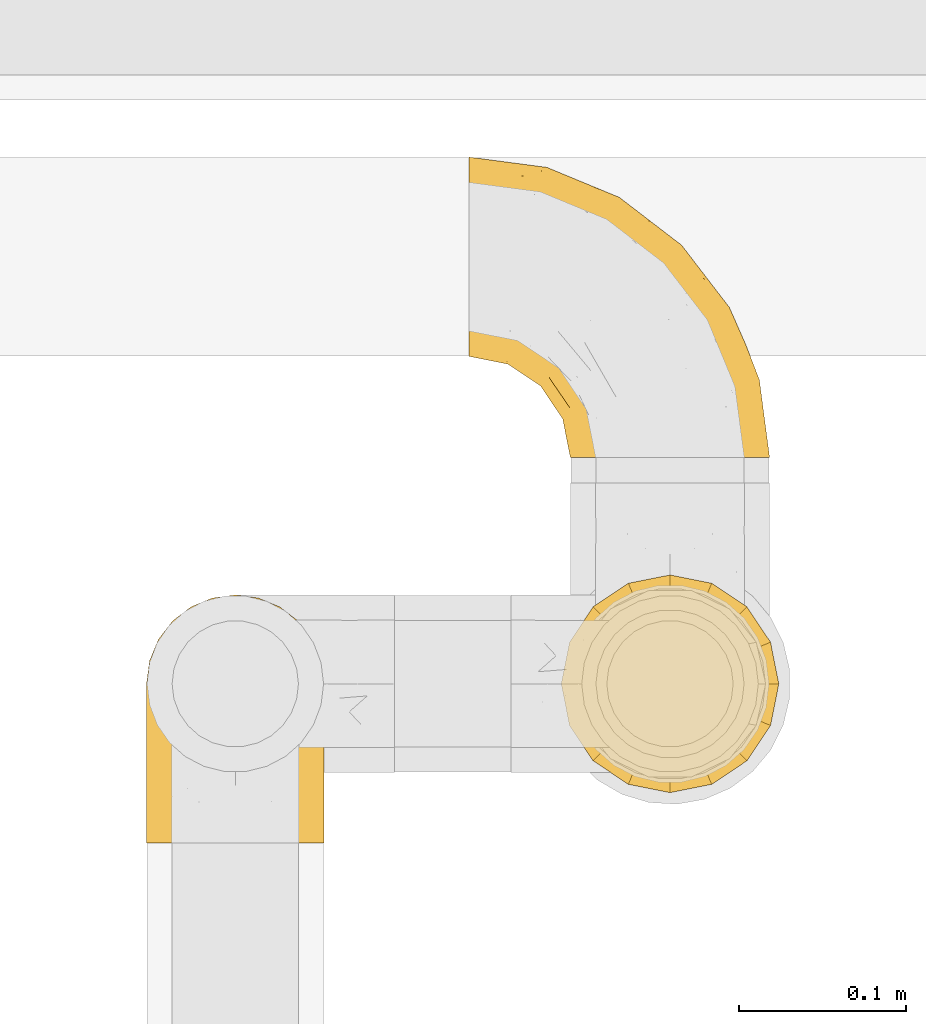
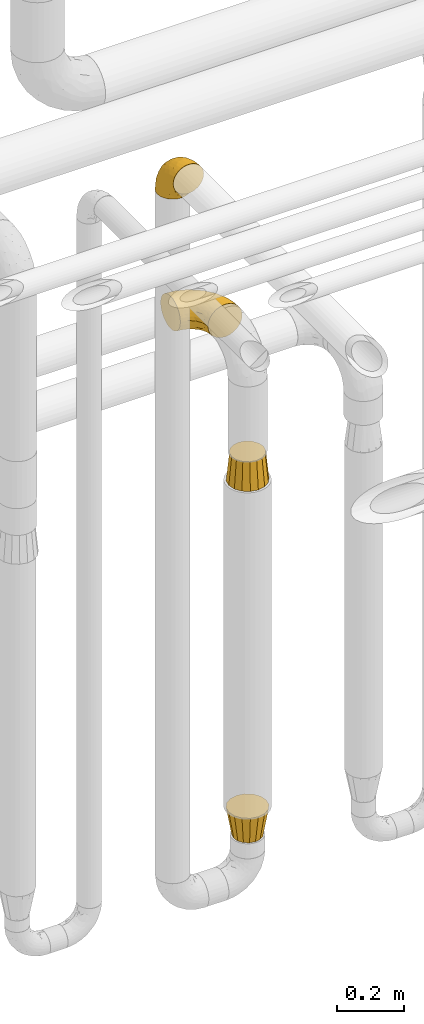
# One storey, part 477 of 827: 4 coverings.
"""IFC2X3 building model written with IfcOpenShell, lengths in millimetres."""

from ifc_helpers import new_model, entity, si_unit, converted_unit, derived_unit, direction, frame, origin, place, context, subcontext, project, spatial, faceted_brep, element, save


model = new_model("IFC2X3")

# Units and contexts
model_context = context("Model", 3, precision=0.01, world=origin(), true_north=direction((6.12303176911189e-17, 1.0)))
body_context = subcontext(model_context, "Body", "Model", "MODEL_VIEW")
ifc_project = project(units=[si_unit("LENGTHUNIT", "METRE", prefix="MILLI"), si_unit("AREAUNIT", "SQUARE_METRE"), si_unit("VOLUMEUNIT", "CUBIC_METRE"), converted_unit("PLANEANGLEUNIT", "DEGREE", entity("IfcRatioMeasure", 0.0174532925199433), si_unit("PLANEANGLEUNIT", "RADIAN"), dimensions=[0, 0, 0, 0, 0, 0, 0]), si_unit("MASSUNIT", "GRAM", prefix="KILO"), derived_unit("MASSDENSITYUNIT", [(si_unit("MASSUNIT", "GRAM", prefix="KILO"), 1), (si_unit("LENGTHUNIT", "METRE"), -3)]), derived_unit("MOMENTOFINERTIAUNIT", [(si_unit("LENGTHUNIT", "METRE"), 4)]), si_unit("TIMEUNIT", "SECOND"), si_unit("FREQUENCYUNIT", "HERTZ"), si_unit("THERMODYNAMICTEMPERATUREUNIT", "DEGREE_CELSIUS"), derived_unit("THERMALTRANSMITTANCEUNIT", [(si_unit("MASSUNIT", "GRAM", prefix="KILO"), 1), (si_unit("THERMODYNAMICTEMPERATUREUNIT", "KELVIN"), -1), (si_unit("TIMEUNIT", "SECOND"), -3)]), derived_unit("VOLUMETRICFLOWRATEUNIT", [(si_unit("LENGTHUNIT", "METRE"), 3), (si_unit("TIMEUNIT", "SECOND"), -1)]), derived_unit("MASSFLOWRATEUNIT", [(si_unit("MASSUNIT", "GRAM", prefix="KILO"), 1), (si_unit("TIMEUNIT", "SECOND"), -1)]), derived_unit("ROTATIONALFREQUENCYUNIT", [(si_unit("TIMEUNIT", "SECOND"), -1)]), si_unit("ELECTRICCURRENTUNIT", "AMPERE"), si_unit("ELECTRICVOLTAGEUNIT", "VOLT"), si_unit("POWERUNIT", "WATT"), si_unit("FORCEUNIT", "NEWTON", prefix="KILO"), si_unit("ILLUMINANCEUNIT", "LUX"), si_unit("LUMINOUSFLUXUNIT", "LUMEN"), si_unit("LUMINOUSINTENSITYUNIT", "CANDELA"), derived_unit("USERDEFINED", [(si_unit("MASSUNIT", "GRAM", prefix="KILO"), -1), (si_unit("LENGTHUNIT", "METRE"), -2), (si_unit("TIMEUNIT", "SECOND"), 3), (si_unit("LUMINOUSFLUXUNIT", "LUMEN"), 1)]), derived_unit("LINEARVELOCITYUNIT", [(si_unit("LENGTHUNIT", "METRE"), 1), (si_unit("TIMEUNIT", "SECOND"), -1)]), si_unit("PRESSUREUNIT", "PASCAL"), derived_unit("USERDEFINED", [(si_unit("LENGTHUNIT", "METRE"), -2), (si_unit("MASSUNIT", "GRAM", prefix="KILO"), 1), (si_unit("TIMEUNIT", "SECOND"), -2)]), derived_unit("LINEARFORCEUNIT", [(si_unit("MASSUNIT", "GRAM", prefix="KILO"), 1), (si_unit("LENGTHUNIT", "METRE"), 1), (si_unit("TIMEUNIT", "SECOND"), -2), (si_unit("LENGTHUNIT", "METRE"), -1)]), derived_unit("PLANARFORCEUNIT", [(si_unit("MASSUNIT", "GRAM", prefix="KILO"), 1), (si_unit("LENGTHUNIT", "METRE"), 1), (si_unit("TIMEUNIT", "SECOND"), -2), (si_unit("LENGTHUNIT", "METRE"), -2)])], contexts=[model_context])

# Site, building, storey
site_placement = place(None, origin())
site = spatial("IfcSite", under=ifc_project, at=site_placement, CompositionType="ELEMENT")
building_placement = place(site_placement, origin())
building = spatial("IfcBuilding", under=site, at=building_placement, CompositionType="ELEMENT")
storey_placement = place(building_placement, frame((0.0, 0.0, 28200.0)))
storey = spatial("IfcBuildingStorey", under=building, at=storey_placement, Name="08", CompositionType="ELEMENT", Elevation=28200.0)

# Coverings
covering_1_placement = place(storey_placement, frame((57933.24, 17403.4, 2953.4)))
element("IfcCovering", 1, at=covering_1_placement, inside=storey, Name=":ADSK_", ObjectType=":ADSK_", PredefinedType="INSULATION", context=body_context, shape_type="Brep", body=[
    faceted_brep([(66.44, 1.6, 148.32), (54.65, 1.6, 149.65), (42.84, 1.6, 148.31), (31.62, 1.6, 144.39), (21.56, 1.6, 138.06), (13.16, 1.6, 129.66), (6.84, 1.6, 119.6), (2.92, 1.6, 108.39), (1.6, 1.6, 96.6), (2.93, 1.6, 84.79), (6.85, 1.6, 73.57), (13.18, 1.6, 63.51), (21.58, 1.6, 55.11), (31.64, 1.6, 48.79), (42.85, 1.6, 44.87), (54.65, 1.6, 43.55), (66.46, 1.6, 44.88), (77.67, 1.6, 48.8), (87.73, 1.6, 55.13), (96.13, 1.6, 63.53), (102.45, 1.6, 73.59), (106.37, 1.6, 84.8), (107.7, 1.6, 96.6), (106.36, 1.6, 108.41), (102.44, 1.6, 119.62), (96.11, 1.6, 129.68), (87.71, 1.6, 138.08), (77.65, 1.6, 144.4), (40.91, 45.35, 1.6), (28.12, 50.65, 1.6), (17.13, 59.08, 1.6), (8.7, 70.07, 1.6), (3.4, 82.86, 1.6), (1.6, 96.6, 1.6), (3.4, 110.33, 1.6), (8.7, 123.12, 1.6), (17.13, 134.11, 1.6), (28.12, 142.54, 1.6), (40.91, 147.84, 1.6), (54.65, 149.65, 1.6), (68.38, 147.84, 1.6), (81.17, 142.54, 1.6), (92.16, 134.11, 1.6), (100.59, 123.12, 1.6), (105.89, 110.33, 1.6), (107.7, 96.6, 1.6), (105.89, 82.86, 1.6), (100.59, 70.07, 1.6), (92.16, 59.08, 1.6), (81.17, 50.65, 1.6), (68.38, 45.35, 1.6), (54.65, 43.55, 1.6), (85.53, 137.19, 27.97), (73.42, 141.79, 37.09), (83.77, 128.89, 58.27), (64.22, 146.54, 27.13), (54.65, 144.6, 39.91), (96.72, 69.77, 109.11), (93.36, 94.41, 94.41), (84.47, 87.22, 110.94), (71.37, 117.2, 89.69), (54.65, 129.81, 75.62), (54.65, 106.28, 106.28), (103.47, 101.45, 60.12), (100.91, 115.81, 41.41), (99.1, 109.14, 63.22), (105.43, 107.65, 32.05), (106.79, 93.36, 52.13), (89.81, 59.44, 123.27), (79.59, 63.23, 129.32), (81.29, 35.59, 138.3), (74.01, 132.3, 62.95), (64.14, 138.41, 55.89), (94.75, 126.28, 37.4), (54.65, 39.91, 144.6), (70.74, 37.44, 142.66), (68.3, 90.35, 117.85), (66.05, 65.0, 134.01), (100.73, 85.4, 89.25), (106.78, 26.66, 103.34), (103.6, 29.88, 113.52), (107.7, 78.45, 57.43), (107.7, 85.2, 44.19), (107.7, 91.95, 30.95), (106.07, 77.98, 77.98), (90.59, 29.55, 132.66), (97.43, 41.42, 121.52), (84.51, 111.13, 86.93), (93.3, 114.67, 68.4), (107.7, 57.43, 78.45), (107.7, 67.94, 67.94), (107.7, 14.64, 94.53), (107.7, 30.95, 91.95), (106.79, 52.13, 93.36), (107.7, 44.19, 85.2), (103.47, 60.12, 101.45), (54.65, 75.62, 129.81), (107.7, 94.27, 16.27), (76.99, 24.59, 42.46), (84.28, 34.69, 40.4), (91.11, 31.15, 49.71), (106.26, 75.18, 39.4), (102.6, 67.55, 31.26), (106.08, 79.36, 27.7), (106.56, 84.32, 16.7), (105.36, 40.81, 70.67), (106.74, 29.93, 81.69), (101.59, 70.24, 16.68), (54.65, 37.93, 22.57), (54.65, 40.15, 14.26), (67.71, 42.1, 17.68), (91.36, 55.38, 19.58), (94.33, 52.17, 33.49), (87.1, 44.32, 33.01), (65.84, 19.85, 40.69), (54.65, 14.26, 40.15), (54.65, 22.57, 37.93), (68.92, 34.17, 31.04), (100.82, 54.85, 45.29), (79.83, 44.63, 23.55), (77.13, 47.52, 11.36), (105.9, 59.1, 59.1), (101.53, 44.11, 57.42), (106.72, 53.21, 68.96), (97.75, 62.86, 20.38), (103.08, 20.58, 72.46), (106.39, 15.79, 83.66), (98.1, 27.67, 60.66), (95.02, 13.49, 61.01), (86.9, 18.04, 51.85), (74.42, 12.44, 46.07), (54.65, 30.25, 30.25), (105.28, 66.71, 46.65), (92.87, 42.52, 43.0), (17.93, 55.38, 19.58), (6.22, 20.57, 72.44), (41.58, 42.11, 17.67), (1.6, 57.43, 78.45), (2.57, 53.22, 68.97), (3.94, 40.81, 70.65), (43.46, 19.85, 40.69), (32.32, 24.58, 42.45), (40.38, 34.16, 31.04), (16.44, 42.5, 42.99), (8.47, 54.93, 45.18), (15.01, 52.13, 33.46), (11.21, 27.66, 60.64), (7.78, 44.12, 57.37), (1.6, 78.45, 57.43), (1.6, 85.2, 44.19), (3.04, 75.17, 39.35), (1.6, 94.27, 16.27), (2.73, 84.32, 16.7), (1.6, 30.95, 91.95), (1.6, 44.19, 85.2), (2.55, 29.98, 81.68), (3.98, 66.78, 46.68), (6.69, 67.55, 31.26), (7.7, 70.24, 16.68), (3.21, 79.36, 27.7), (14.28, 13.48, 60.99), (22.42, 18.03, 51.84), (25.02, 34.66, 40.41), (18.18, 31.14, 49.72), (34.89, 12.43, 46.06), (1.6, 14.64, 94.53), (32.17, 47.52, 11.35), (22.23, 44.28, 33.02), (2.91, 15.8, 83.65), (11.54, 62.86, 20.38), (1.6, 67.94, 67.94), (29.46, 44.64, 23.53), (3.38, 59.12, 59.12), (1.6, 91.95, 30.95), (25.52, 128.89, 58.27), (23.76, 137.19, 27.97), (14.54, 126.28, 37.4), (8.38, 115.81, 41.41), (45.07, 146.53, 27.21), (35.87, 141.79, 37.09), (45.14, 139.45, 53.2), (2.5, 93.36, 52.13), (2.51, 26.67, 103.34), (5.68, 29.87, 113.5), (5.82, 60.12, 101.45), (15.93, 94.41, 94.41), (12.54, 69.76, 109.08), (24.81, 87.19, 110.95), (2.5, 52.13, 93.36), (3.22, 77.98, 77.98), (3.86, 107.65, 32.05), (35.85, 131.74, 64.63), (19.47, 59.44, 123.25), (18.68, 29.54, 132.65), (29.68, 63.2, 129.32), (27.95, 27.9, 139.96), (40.99, 90.35, 117.85), (37.92, 117.2, 89.69), (11.85, 41.39, 121.51), (10.19, 109.14, 63.23), (8.55, 85.46, 89.17), (38.53, 37.43, 142.66), (15.99, 114.67, 68.4), (24.79, 111.12, 86.94), (5.82, 101.45, 60.12), (40.56, 65.16, 133.2)], [[[0, 1, 2, 3, 4, 5, 6, 7, 8, 9, 10, 11, 12, 13, 14, 15, 16, 17, 18, 19, 20, 21, 22, 23, 24, 25, 26, 27]], [[28, 29, 30, 31, 32, 33, 34, 35, 36, 37, 38, 39, 40, 41, 42, 43, 44, 45, 46, 47, 48, 49, 50, 51]], [[52, 53, 54]], [[55, 39, 56]], [[57, 58, 59]], [[60, 61, 62]], [[63, 64, 65]], [[66, 63, 67]], [[68, 69, 70]], [[53, 71, 54]], [[41, 40, 53]], [[53, 72, 71]], [[73, 42, 52]], [[42, 41, 52]], [[74, 0, 75]], [[69, 76, 77]], [[43, 73, 64]], [[45, 44, 66]], [[57, 78, 58]], [[23, 79, 80]], [[67, 81, 82, 83]], [[67, 84, 81]], [[24, 23, 80]], [[25, 85, 26]], [[86, 85, 25]], [[42, 73, 43]], [[0, 27, 75]], [[25, 24, 86]], [[70, 26, 85]], [[0, 74, 1]], [[68, 85, 86]], [[66, 64, 63]], [[60, 59, 87]], [[54, 87, 88]], [[76, 60, 62]], [[84, 89, 90, 81]], [[79, 22, 91, 92]], [[77, 74, 75]], [[93, 92, 94, 89]], [[80, 86, 24]], [[40, 55, 53]], [[76, 59, 60]], [[93, 84, 95]], [[76, 62, 96]], [[55, 72, 53]], [[70, 27, 26]], [[75, 70, 69]], [[78, 84, 63]], [[93, 79, 92]], [[95, 86, 80]], [[77, 76, 96]], [[59, 69, 68]], [[57, 68, 86]], [[68, 57, 59]], [[59, 58, 87]], [[76, 69, 59]], [[88, 87, 58]], [[87, 54, 71]], [[86, 95, 57]], [[78, 57, 95]], [[84, 78, 95]], [[78, 63, 65]], [[58, 78, 65]], [[54, 88, 73]], [[84, 93, 89]], [[79, 95, 80]], [[79, 93, 95]], [[22, 79, 23]], [[66, 83, 97, 45]], [[84, 67, 63]], [[83, 66, 67]], [[64, 44, 43]], [[64, 66, 44]], [[65, 73, 88]], [[53, 52, 41]], [[73, 52, 54]], [[73, 65, 64]], [[65, 88, 58]], [[39, 55, 40]], [[72, 55, 56]], [[56, 61, 72]], [[60, 72, 61]], [[72, 60, 71]], [[87, 71, 60]], [[27, 70, 75]], [[68, 70, 85]], [[74, 77, 96]], [[69, 77, 75]], [[98, 99, 100]], [[46, 45, 97]], [[101, 102, 103]], [[103, 104, 83]], [[105, 94, 106]], [[107, 103, 102]], [[108, 109, 51, 110]], [[111, 112, 113]], [[114, 115, 116]], [[47, 104, 107]], [[110, 117, 108]], [[49, 48, 111]], [[102, 118, 112]], [[119, 120, 111]], [[50, 49, 120]], [[121, 122, 118]], [[105, 123, 89]], [[124, 48, 107]], [[20, 19, 125]], [[121, 81, 90]], [[117, 119, 99]], [[21, 20, 126]], [[22, 21, 91]], [[105, 125, 127]], [[110, 51, 50]], [[19, 128, 125]], [[16, 15, 115]], [[129, 98, 100]], [[126, 91, 21]], [[128, 129, 127]], [[122, 123, 105]], [[114, 117, 98]], [[17, 16, 130]], [[18, 128, 19]], [[129, 18, 17]], [[125, 106, 126]], [[115, 114, 16]], [[130, 129, 17]], [[114, 98, 130]], [[117, 116, 131, 108]], [[99, 119, 113]], [[122, 121, 123]], [[92, 126, 106]], [[105, 127, 122]], [[132, 121, 118]], [[114, 130, 16]], [[129, 130, 98]], [[50, 120, 110]], [[129, 128, 18]], [[125, 128, 127]], [[125, 126, 20]], [[91, 126, 92]], [[105, 89, 94]], [[105, 106, 125]], [[94, 92, 106]], [[100, 122, 127]], [[118, 122, 133]], [[112, 118, 133]], [[132, 118, 102]], [[132, 102, 101]], [[81, 121, 132]], [[82, 103, 83]], [[132, 101, 81]], [[104, 47, 46]], [[124, 107, 102]], [[48, 47, 107]], [[113, 112, 133]], [[112, 111, 124]], [[99, 113, 133]], [[111, 113, 119]], [[99, 133, 100]], [[117, 99, 98]], [[122, 100, 133]], [[127, 129, 100]], [[103, 82, 101]], [[81, 101, 82]], [[112, 124, 102]], [[48, 124, 111]], [[104, 103, 107]], [[46, 97, 104]], [[111, 120, 49]], [[83, 104, 97]], [[110, 120, 119]], [[117, 110, 119]], [[116, 117, 114]], [[89, 123, 90]], [[90, 123, 121]], [[30, 29, 134]], [[11, 10, 135]], [[51, 109, 108, 136]], [[137, 138, 139]], [[140, 141, 142]], [[143, 144, 145]], [[146, 139, 147]], [[148, 149, 150]], [[151, 32, 152]], [[153, 154, 155]], [[156, 150, 157]], [[158, 157, 159]], [[108, 142, 136]], [[31, 158, 152]], [[160, 161, 12]], [[162, 163, 143]], [[140, 142, 116]], [[142, 141, 162]], [[14, 164, 140]], [[14, 140, 115]], [[9, 8, 165]], [[160, 12, 11]], [[141, 164, 161]], [[13, 12, 161]], [[14, 115, 15]], [[28, 166, 29]], [[135, 139, 146]], [[141, 163, 162]], [[135, 146, 160]], [[143, 167, 162]], [[29, 166, 134]], [[116, 142, 108, 131]], [[165, 153, 168]], [[10, 9, 168]], [[168, 135, 10]], [[138, 147, 139]], [[158, 169, 157]], [[14, 13, 164]], [[116, 115, 140]], [[145, 167, 143]], [[135, 160, 11]], [[168, 153, 155]], [[138, 137, 170]], [[157, 144, 156]], [[147, 144, 143]], [[161, 164, 13]], [[140, 164, 141]], [[142, 171, 136]], [[136, 171, 166]], [[161, 160, 146]], [[165, 168, 9]], [[155, 139, 135]], [[139, 154, 137]], [[168, 155, 135]], [[139, 155, 154]], [[144, 147, 172]], [[163, 147, 143]], [[156, 144, 172]], [[157, 169, 145]], [[172, 148, 156]], [[173, 159, 149]], [[159, 157, 150]], [[152, 159, 173]], [[159, 152, 158]], [[31, 30, 158]], [[169, 30, 134]], [[157, 145, 144]], [[167, 134, 171]], [[134, 167, 145]], [[171, 142, 162]], [[162, 167, 171]], [[163, 141, 161]], [[161, 146, 163]], [[147, 163, 146]], [[148, 150, 156]], [[149, 159, 150]], [[30, 169, 158]], [[145, 169, 134]], [[151, 33, 32]], [[31, 152, 32]], [[152, 173, 151]], [[28, 51, 136]], [[134, 166, 171]], [[28, 136, 166]], [[138, 170, 172]], [[147, 138, 172]], [[148, 172, 170]], [[174, 175, 176]], [[35, 34, 177]], [[178, 179, 180]], [[181, 173, 149, 148]], [[182, 183, 184]], [[185, 186, 187]], [[188, 189, 137]], [[190, 33, 151, 173]], [[191, 179, 174]], [[34, 190, 177]], [[39, 38, 178]], [[192, 193, 194]], [[4, 3, 195]], [[175, 179, 37]], [[38, 37, 179]], [[35, 176, 36]], [[196, 62, 197]], [[181, 190, 173]], [[37, 36, 175]], [[183, 6, 198]], [[189, 148, 170, 137]], [[185, 199, 200]], [[3, 2, 201]], [[202, 185, 203]], [[8, 7, 182]], [[200, 184, 186]], [[183, 7, 6]], [[181, 189, 204]], [[200, 189, 184]], [[5, 198, 6]], [[187, 203, 185]], [[195, 3, 201]], [[205, 196, 194]], [[62, 61, 197]], [[186, 198, 192]], [[180, 179, 191]], [[2, 1, 74]], [[198, 193, 192]], [[193, 5, 4]], [[194, 193, 195]], [[2, 74, 201]], [[5, 193, 198]], [[205, 74, 96]], [[188, 137, 154, 153]], [[62, 196, 96]], [[56, 178, 180]], [[198, 184, 183]], [[184, 188, 182]], [[203, 197, 191]], [[205, 194, 201]], [[187, 192, 194]], [[192, 187, 186]], [[194, 196, 187]], [[197, 187, 196]], [[197, 203, 187]], [[202, 174, 176]], [[200, 186, 185]], [[184, 198, 186]], [[199, 185, 202]], [[189, 200, 204]], [[174, 202, 203]], [[176, 177, 199]], [[189, 181, 148]], [[190, 181, 204]], [[190, 204, 177]], [[190, 34, 33]], [[188, 153, 182]], [[189, 188, 184]], [[182, 153, 165, 8]], [[183, 182, 7]], [[199, 177, 204]], [[35, 177, 176]], [[176, 175, 36]], [[179, 175, 174]], [[200, 199, 204]], [[176, 199, 202]], [[203, 191, 174]], [[180, 197, 61]], [[197, 180, 191]], [[61, 56, 180]], [[39, 178, 56]], [[38, 179, 178]], [[194, 195, 201]], [[4, 195, 193]], [[74, 205, 201]], [[96, 196, 205]]]),
])
covering_2_placement = place(storey_placement, frame((58125.97, 17633.5, 2238.9)))
element("IfcCovering", 2, at=covering_2_placement, inside=storey, Name=":ADSK_", ObjectType=":ADSK_", PredefinedType="INSULATION", context=body_context, shape_type="Brep", body=[
    faceted_brep([(1.6, 134.84, 119.1), (1.6, 147.42, 114.7), (1.6, 158.7, 107.61), (1.6, 168.12, 98.19), (1.6, 175.21, 86.9), (1.6, 179.61, 74.32), (1.6, 181.1, 61.1), (1.6, 179.6, 47.85), (1.6, 175.2, 35.28), (1.6, 168.11, 23.99), (1.6, 158.69, 14.57), (1.6, 147.4, 7.48), (1.6, 134.82, 3.08), (1.6, 121.6, 1.6), (1.6, 108.35, 3.09), (1.6, 95.78, 7.49), (1.6, 84.49, 14.58), (1.6, 75.07, 24.0), (1.6, 67.98, 35.29), (1.6, 63.58, 47.87), (1.6, 62.1, 61.1), (1.6, 63.59, 74.34), (1.6, 67.99, 86.92), (1.6, 75.08, 98.2), (1.6, 84.5, 107.62), (1.6, 95.79, 114.71), (1.6, 108.37, 119.11), (1.6, 121.6, 120.6), (64.12, 1.6, 45.7), (70.07, 1.6, 31.35), (79.52, 1.6, 19.02), (91.85, 1.6, 9.57), (106.2, 1.6, 3.62), (121.6, 1.6, 1.6), (137.0, 1.6, 3.62), (151.35, 1.6, 9.57), (163.67, 1.6, 19.02), (173.12, 1.6, 31.35), (179.07, 1.6, 45.7), (181.1, 1.6, 61.1), (179.07, 1.6, 76.5), (173.12, 1.6, 90.85), (163.67, 1.6, 103.17), (151.35, 1.6, 112.62), (137.0, 1.6, 118.57), (121.6, 1.6, 120.6), (106.2, 1.6, 118.57), (91.85, 1.6, 112.62), (79.52, 1.6, 103.17), (70.07, 1.6, 90.85), (64.12, 1.6, 76.5), (62.1, 1.6, 61.1), (166.85, 33.33, 95.88), (171.8, 44.74, 82.3), (156.7, 69.96, 94.1), (175.89, 40.16, 71.89), (174.98, 48.05, 61.1), (34.39, 151.91, 110.03), (141.86, 108.53, 80.11), (157.05, 91.35, 61.1), (128.52, 128.52, 61.1), (125.77, 73.53, 115.76), (142.49, 50.18, 113.03), (137.62, 82.09, 106.83), (133.72, 39.2, 118.0), (116.57, 64.44, 119.56), (116.34, 128.8, 91.22), (137.54, 98.47, 97.67), (160.1, 76.37, 83.16), (166.8, 69.24, 71.84), (154.26, 45.01, 106.27), (48.05, 174.98, 61.1), (44.99, 172.83, 79.29), (75.77, 157.13, 89.43), (109.34, 142.66, 76.37), (78.35, 162.33, 73.84), (96.98, 96.98, 118.7), (106.86, 106.81, 113.14), (67.36, 131.43, 114.84), (49.85, 125.87, 119.09), (72.13, 98.68, 120.6), (98.68, 72.13, 120.6), (107.2, 55.4, 120.6), (115.72, 38.68, 120.6), (91.35, 157.05, 61.1), (45.24, 159.74, 101.09), (73.45, 142.54, 106.71), (33.95, 169.74, 91.36), (32.97, 140.66, 116.15), (16.23, 119.28, 120.6), (38.68, 115.72, 120.6), (74.48, 150.8, 98.77), (85.4, 85.4, 120.6), (115.39, 115.39, 104.27), (55.4, 107.2, 120.6), (119.28, 16.23, 120.6), (85.98, 41.33, 114.26), (71.16, 60.97, 113.3), (70.35, 44.53, 106.08), (103.0, 22.81, 118.29), (94.6, 54.61, 119.17), (55.86, 56.46, 102.39), (81.81, 71.82, 119.07), (60.95, 19.73, 74.66), (52.54, 36.08, 72.06), (57.49, 24.75, 61.1), (24.83, 80.61, 107.18), (37.73, 70.66, 103.18), (50.74, 75.33, 111.64), (87.65, 19.78, 111.23), (74.24, 24.82, 101.44), (15.74, 64.62, 82.78), (20.12, 70.97, 95.99), (61.93, 31.11, 88.46), (65.86, 15.08, 85.34), (40.95, 49.76, 75.22), (44.38, 44.38, 61.1), (38.05, 92.49, 116.35), (55.63, 95.6, 119.46), (56.15, 84.24, 116.78), (31.75, 59.82, 85.13), (49.11, 49.86, 89.52), (20.72, 106.17, 119.0), (32.8, 65.21, 94.63), (18.32, 92.7, 113.92), (24.08, 59.21, 73.67), (24.75, 57.49, 61.1), (70.12, 85.25, 119.4), (61.67, 42.75, 97.35), (41.55, 102.97, 119.56), (96.92, 37.13, 117.72), (81.07, 30.22, 108.82), (70.33, 44.52, 16.12), (55.85, 56.45, 19.81), (71.15, 60.95, 8.9), (20.12, 70.96, 26.21), (24.84, 80.6, 15.02), (61.65, 42.75, 24.86), (38.08, 92.47, 5.84), (41.53, 102.97, 2.63), (55.63, 95.61, 2.73), (40.93, 49.78, 46.99), (60.95, 19.73, 47.54), (65.86, 15.08, 36.85), (87.65, 19.78, 10.96), (81.07, 30.22, 13.37), (85.98, 41.33, 7.93), (94.6, 54.61, 3.02), (84.2, 70.62, 2.89), (98.68, 72.13, 1.6), (103.0, 22.81, 3.9), (119.28, 16.23, 1.6), (40.95, 61.01, 26.96), (31.73, 59.83, 37.08), (74.24, 24.81, 20.75), (50.74, 75.31, 10.56), (52.54, 36.08, 50.11), (37.73, 70.64, 19.02), (24.06, 59.21, 48.54), (68.67, 80.97, 3.81), (18.33, 92.68, 8.27), (96.92, 37.13, 4.47), (15.72, 64.62, 39.43), (20.72, 106.16, 3.19), (49.08, 49.88, 32.68), (38.68, 115.72, 1.6), (16.23, 119.28, 1.6), (55.4, 107.2, 1.6), (51.76, 85.63, 5.87), (85.4, 85.4, 1.6), (115.72, 38.68, 1.6), (107.2, 55.4, 1.6), (72.13, 98.68, 1.6), (61.93, 31.1, 33.73), (156.7, 69.96, 28.09), (166.85, 33.33, 26.31), (154.26, 45.01, 15.92), (142.49, 50.18, 9.16), (175.89, 40.16, 50.3), (171.8, 44.74, 39.89), (166.8, 69.24, 50.35), (116.57, 64.44, 2.63), (137.62, 82.09, 15.36), (109.34, 142.66, 45.82), (116.34, 128.8, 30.97), (75.76, 157.13, 32.75), (96.98, 96.98, 3.49), (133.72, 39.2, 4.19), (160.1, 76.37, 39.03), (78.71, 161.18, 44.85), (44.98, 172.83, 42.89), (141.86, 108.53, 42.08), (32.97, 140.65, 6.03), (49.86, 125.85, 3.1), (125.77, 73.53, 6.43), (106.86, 106.81, 9.05), (34.39, 151.89, 12.15), (45.23, 159.73, 21.09), (137.54, 98.47, 24.52), (33.95, 169.73, 30.82), (67.37, 131.41, 7.35), (73.45, 142.53, 15.47), (115.39, 115.39, 17.92), (74.47, 150.79, 23.41)], [[[0, 1, 2, 3, 4, 5, 6, 7, 8, 9, 10, 11, 12, 13, 14, 15, 16, 17, 18, 19, 20, 21, 22, 23, 24, 25, 26, 27]], [[28, 29, 30, 31, 32, 33, 34, 35, 36, 37, 38, 39, 40, 41, 42, 43, 44, 45, 46, 47, 48, 49, 50, 51]], [[52, 53, 54]], [[55, 39, 56]], [[57, 2, 1]], [[58, 59, 60]], [[61, 62, 63]], [[64, 61, 65]], [[58, 66, 67]], [[53, 68, 54]], [[41, 40, 53]], [[53, 69, 68]], [[70, 42, 52]], [[42, 41, 52]], [[71, 5, 72]], [[73, 74, 75]], [[43, 70, 62]], [[45, 44, 64]], [[76, 77, 78]], [[79, 80, 76]], [[65, 81, 82, 83]], [[74, 60, 84]], [[85, 2, 57]], [[85, 57, 86]], [[2, 85, 3]], [[42, 70, 43]], [[5, 4, 72]], [[72, 87, 73]], [[4, 3, 87]], [[5, 71, 6]], [[75, 74, 84]], [[64, 62, 61]], [[79, 78, 88]], [[54, 67, 63]], [[74, 58, 60]], [[65, 76, 81]], [[79, 27, 89, 90]], [[75, 71, 72]], [[85, 86, 91]], [[78, 57, 88]], [[56, 69, 55]], [[76, 78, 79]], [[76, 80, 92, 81]], [[77, 76, 61]], [[69, 56, 59]], [[4, 87, 72]], [[91, 66, 73]], [[58, 74, 66]], [[3, 85, 87]], [[73, 87, 85]], [[88, 57, 1]], [[86, 57, 78]], [[77, 86, 78]], [[93, 66, 91]], [[73, 66, 74]], [[67, 93, 63]], [[1, 0, 88]], [[0, 27, 79]], [[0, 79, 88]], [[79, 90, 94, 80]], [[64, 83, 95, 45]], [[76, 65, 61]], [[83, 64, 65]], [[62, 44, 43]], [[62, 64, 44]], [[63, 62, 70]], [[54, 63, 70]], [[63, 93, 77]], [[63, 77, 61]], [[77, 93, 86]], [[67, 54, 68]], [[66, 93, 67]], [[53, 52, 41]], [[70, 52, 54]], [[58, 69, 59]], [[55, 69, 53]], [[69, 58, 68]], [[67, 68, 58]], [[53, 40, 55]], [[39, 55, 40]], [[71, 75, 84]], [[73, 75, 72]], [[91, 86, 93]], [[73, 85, 91]], [[96, 97, 98]], [[83, 99, 95]], [[82, 81, 100]], [[95, 99, 46]], [[101, 98, 97]], [[47, 46, 99]], [[97, 100, 102]], [[103, 104, 105]], [[106, 107, 108]], [[109, 48, 47]], [[48, 110, 49]], [[108, 101, 97]], [[111, 112, 22]], [[51, 50, 103]], [[113, 103, 114]], [[23, 22, 112]], [[115, 116, 104]], [[108, 117, 106]], [[112, 106, 23]], [[94, 118, 80]], [[108, 119, 117]], [[120, 115, 121]], [[112, 107, 106]], [[25, 122, 26]], [[122, 89, 26]], [[101, 123, 121]], [[109, 110, 48]], [[124, 25, 24]], [[125, 20, 126]], [[120, 111, 125]], [[110, 113, 114]], [[127, 97, 102]], [[106, 24, 23]], [[125, 115, 120]], [[111, 22, 21]], [[126, 115, 125]], [[117, 124, 106]], [[110, 98, 128]], [[117, 129, 124]], [[117, 118, 129]], [[100, 97, 96]], [[124, 122, 25]], [[83, 82, 130]], [[99, 130, 109]], [[100, 81, 102]], [[100, 130, 82]], [[130, 100, 96]], [[81, 92, 102]], [[127, 80, 118]], [[21, 20, 125]], [[111, 120, 123]], [[21, 125, 111]], [[115, 126, 116]], [[104, 116, 105]], [[101, 107, 123]], [[104, 121, 115]], [[128, 121, 113]], [[105, 51, 103]], [[121, 104, 113]], [[114, 103, 50]], [[113, 104, 103]], [[106, 124, 24]], [[94, 129, 118]], [[123, 107, 112]], [[101, 108, 107]], [[99, 109, 47]], [[131, 109, 96]], [[89, 122, 90]], [[89, 27, 26]], [[122, 129, 90]], [[97, 127, 119]], [[119, 127, 118]], [[102, 92, 127]], [[90, 129, 94]], [[80, 127, 92]], [[124, 129, 122]], [[117, 119, 118]], [[97, 119, 108]], [[50, 49, 114]], [[110, 114, 49]], [[109, 130, 96]], [[130, 99, 83]], [[128, 98, 101]], [[98, 110, 131]], [[121, 128, 101]], [[110, 128, 113]], [[46, 45, 95]], [[111, 123, 112]], [[121, 123, 120]], [[98, 131, 96]], [[110, 109, 131]], [[132, 133, 134]], [[135, 17, 136]], [[132, 137, 133]], [[138, 139, 140]], [[126, 141, 116]], [[105, 142, 51]], [[16, 136, 17]], [[142, 143, 28]], [[144, 145, 146]], [[147, 148, 149]], [[31, 150, 32]], [[150, 151, 32]], [[135, 152, 153]], [[30, 29, 154]], [[155, 136, 138]], [[31, 30, 144]], [[156, 116, 141]], [[136, 155, 157]], [[126, 158, 141]], [[159, 148, 134]], [[20, 19, 158]], [[156, 142, 105]], [[160, 136, 16]], [[147, 161, 146]], [[135, 18, 17]], [[18, 162, 19]], [[136, 157, 135]], [[146, 145, 132]], [[160, 163, 139]], [[16, 15, 160]], [[15, 14, 163]], [[164, 141, 153]], [[133, 155, 134]], [[152, 135, 157]], [[165, 163, 166]], [[163, 14, 166]], [[162, 135, 153]], [[29, 143, 154]], [[165, 167, 139]], [[162, 158, 19]], [[159, 134, 155]], [[167, 140, 139]], [[140, 168, 138]], [[159, 169, 148]], [[144, 150, 31]], [[161, 170, 150]], [[171, 170, 161]], [[149, 171, 147]], [[134, 147, 146]], [[134, 148, 147]], [[135, 162, 18]], [[169, 159, 172]], [[169, 149, 148]], [[158, 162, 153]], [[158, 153, 141]], [[158, 126, 20]], [[153, 152, 164]], [[116, 156, 105]], [[137, 164, 133]], [[156, 164, 173]], [[164, 156, 141]], [[142, 28, 51]], [[156, 173, 142]], [[143, 142, 173]], [[163, 160, 15]], [[136, 160, 138]], [[155, 133, 157]], [[133, 164, 152]], [[154, 144, 30]], [[144, 146, 161]], [[14, 13, 166]], [[172, 159, 140]], [[140, 167, 172]], [[168, 159, 155]], [[160, 139, 138]], [[165, 139, 163]], [[154, 143, 173]], [[29, 28, 143]], [[171, 161, 147]], [[144, 161, 150]], [[159, 168, 140]], [[155, 138, 168]], [[146, 132, 134]], [[137, 154, 173]], [[154, 137, 132]], [[164, 137, 173]], [[151, 150, 170]], [[151, 33, 32]], [[133, 152, 157]], [[144, 154, 145]], [[132, 145, 154]], [[174, 175, 176]], [[35, 34, 177]], [[178, 179, 180]], [[181, 170, 171, 149]], [[176, 182, 174]], [[183, 184, 185]], [[186, 149, 169, 172]], [[187, 33, 151, 170]], [[179, 188, 180]], [[34, 187, 177]], [[39, 38, 178]], [[189, 185, 190]], [[184, 183, 191]], [[175, 179, 37]], [[38, 37, 179]], [[35, 176, 36]], [[180, 59, 56]], [[192, 193, 12]], [[37, 36, 175]], [[181, 187, 170]], [[181, 186, 194]], [[176, 177, 182]], [[8, 7, 190]], [[194, 186, 195]], [[13, 12, 193]], [[196, 192, 11]], [[10, 9, 197]], [[60, 183, 84]], [[174, 182, 198]], [[197, 196, 10]], [[193, 172, 167, 165]], [[8, 199, 9]], [[189, 183, 185]], [[60, 59, 191]], [[200, 196, 201]], [[190, 199, 8]], [[7, 6, 71]], [[10, 196, 11]], [[202, 203, 184]], [[199, 185, 197]], [[7, 71, 190]], [[183, 60, 191]], [[189, 71, 84]], [[193, 186, 172]], [[200, 201, 195]], [[180, 191, 59]], [[185, 199, 190]], [[197, 9, 199]], [[201, 196, 197]], [[192, 196, 200]], [[203, 201, 197]], [[195, 201, 202]], [[191, 188, 198]], [[202, 201, 203]], [[193, 192, 200]], [[12, 11, 192]], [[186, 193, 200]], [[193, 165, 166, 13]], [[186, 181, 149]], [[187, 181, 194]], [[187, 194, 177]], [[187, 34, 33]], [[194, 195, 182]], [[35, 177, 176]], [[194, 182, 177]], [[182, 202, 198]], [[200, 195, 186]], [[182, 195, 202]], [[202, 184, 198]], [[191, 198, 184]], [[176, 175, 36]], [[179, 175, 174]], [[178, 180, 56]], [[179, 174, 188]], [[198, 188, 174]], [[191, 180, 188]], [[39, 178, 56]], [[38, 179, 178]], [[71, 189, 190]], [[84, 183, 189]], [[197, 185, 203]], [[184, 203, 185]]]),
])
covering_3_placement = place(storey_placement, frame((58180.97, 17433.4, 1800.45)))
element("IfcCovering", 3, at=covering_3_placement, inside=storey, Name=":ADSK_", ObjectType=":ADSK_", PredefinedType="INSULATION", context=body_context, shape_type="Brep", body=[
    faceted_brep([(91.47, 6.54, 0.0), (81.18, 4.5, 0.0), (66.6, 1.6, 0.0), (52.01, 4.5, 0.0), (41.72, 6.54, 0.0), (31.18, 13.59, 0.0), (20.63, 20.63, 0.0), (13.59, 31.18, 0.0), (6.54, 41.72, 0.0), (4.5, 52.01, 0.0), (1.6, 66.6, 0.0), (4.5, 81.18, 0.0), (6.54, 91.47, 0.0), (13.59, 102.01, 0.0), (20.63, 112.56, 0.0), (31.18, 119.6, 0.0), (41.72, 126.65, 0.0), (52.01, 128.69, 0.0), (66.6, 131.6, 0.0), (81.18, 128.69, 0.0), (91.47, 126.65, 0.0), (102.01, 119.6, 0.0), (112.56, 112.56, 0.0), (119.6, 102.01, 0.0), (126.65, 91.47, 0.0), (128.69, 81.18, 0.0), (131.6, 66.6, 0.0), (128.69, 52.01, 0.0), (126.65, 41.72, 0.0), (119.6, 31.18, 0.0), (112.56, 20.63, 0.0), (102.01, 13.59, 0.0), (66.6, 11.6, 102.0), (77.12, 13.69, 102.0), (87.64, 15.78, 102.0), (96.56, 21.74, 102.0), (105.49, 27.7, 102.0), (111.45, 36.63, 102.0), (117.41, 45.55, 102.0), (119.5, 56.07, 102.0), (121.6, 66.6, 102.0), (119.5, 77.12, 102.0), (117.41, 87.64, 102.0), (111.45, 96.56, 102.0), (105.49, 105.49, 102.0), (96.56, 111.45, 102.0), (87.64, 117.41, 102.0), (77.12, 119.5, 102.0), (66.6, 121.6, 102.0), (56.07, 119.5, 102.0), (45.55, 117.41, 102.0), (36.63, 111.45, 102.0), (27.7, 105.49, 102.0), (21.74, 96.56, 102.0), (15.78, 87.64, 102.0), (13.69, 77.12, 102.0), (11.6, 66.6, 102.0), (13.69, 56.07, 102.0), (15.78, 45.55, 102.0), (21.74, 36.63, 102.0), (27.7, 27.7, 102.0), (36.63, 21.74, 102.0), (45.55, 15.78, 102.0), (56.07, 13.69, 102.0)], [[[0, 1, 2, 3, 4, 5, 6, 7, 8, 9, 10, 11, 12, 13, 14, 15, 16, 17, 18, 19, 20, 21, 22, 23, 24, 25, 26, 27, 28, 29, 30, 31]], [[32, 33, 34, 35, 36, 37, 38, 39, 40, 41, 42, 43, 44, 45, 46, 47, 48, 49, 50, 51, 52, 53, 54, 55, 56, 57, 58, 59, 60, 61, 62, 63]], [[38, 28, 27, 26, 40, 39]], [[36, 30, 29, 28, 38, 37]], [[34, 0, 31, 30, 36, 35]], [[33, 32, 2, 1, 0, 34]], [[62, 4, 3, 2, 32, 63]], [[60, 6, 5, 4, 62, 61]], [[58, 8, 7, 6, 60, 59]], [[57, 56, 10, 9, 8, 58]], [[54, 12, 11, 10, 56, 55]], [[52, 14, 13, 12, 54, 53]], [[50, 16, 15, 14, 52, 51]], [[49, 48, 18, 17, 16, 50]], [[46, 20, 19, 18, 48, 47]], [[44, 22, 21, 20, 46, 45]], [[42, 24, 23, 22, 44, 43]], [[41, 40, 26, 25, 24, 42]]]),
])
covering_4_placement = place(storey_placement, frame((58180.97, 17433.4, 500.0)))
element("IfcCovering", 4, at=covering_4_placement, inside=storey, Name=":ADSK_", ObjectType=":ADSK_", PredefinedType="INSULATION", context=body_context, shape_type="Brep", body=[
    faceted_brep([(114.1, 66.6, 0.0), (112.29, 57.51, 0.0), (110.48, 48.42, 0.0), (105.33, 40.71, 0.0), (100.18, 33.01, 0.0), (92.48, 27.86, 0.0), (84.77, 22.71, 0.0), (75.68, 20.9, 0.0), (66.6, 19.1, 0.0), (57.51, 20.9, 0.0), (48.42, 22.71, 0.0), (40.71, 27.86, 0.0), (33.01, 33.01, 0.0), (27.86, 40.71, 0.0), (22.71, 48.42, 0.0), (20.9, 57.51, 0.0), (19.1, 66.6, 0.0), (20.9, 75.68, 0.0), (22.71, 84.77, 0.0), (27.86, 92.48, 0.0), (33.01, 100.18, 0.0), (40.71, 105.33, 0.0), (48.42, 110.48, 0.0), (57.51, 112.29, 0.0), (66.6, 114.1, 0.0), (75.68, 112.29, 0.0), (84.77, 110.48, 0.0), (92.48, 105.33, 0.0), (100.18, 100.18, 0.0), (105.33, 92.48, 0.0), (110.48, 84.77, 0.0), (112.29, 75.68, 0.0), (1.6, 66.6, 102.0), (4.38, 52.61, 102.0), (6.54, 41.72, 102.0), (13.59, 31.18, 102.0), (20.63, 20.63, 102.0), (31.18, 13.59, 102.0), (41.72, 6.54, 102.0), (52.61, 4.38, 102.0), (66.6, 1.6, 102.0), (80.58, 4.38, 102.0), (91.47, 6.54, 102.0), (102.01, 13.59, 102.0), (112.56, 20.63, 102.0), (119.6, 31.18, 102.0), (126.65, 41.72, 102.0), (128.81, 52.61, 102.0), (131.6, 66.6, 102.0), (128.81, 80.58, 102.0), (126.65, 91.47, 102.0), (119.6, 102.01, 102.0), (112.56, 112.56, 102.0), (102.01, 119.6, 102.0), (91.47, 126.65, 102.0), (80.58, 128.81, 102.0), (66.6, 131.6, 102.0), (52.61, 128.81, 102.0), (41.72, 126.65, 102.0), (31.18, 119.6, 102.0), (20.63, 112.56, 102.0), (13.59, 102.01, 102.0), (6.54, 91.47, 102.0), (4.38, 80.58, 102.0)], [[[0, 1, 2, 3, 4, 5, 6, 7, 8, 9, 10, 11, 12, 13, 14, 15, 16, 17, 18, 19, 20, 21, 22, 23, 24, 25, 26, 27, 28, 29, 30, 31]], [[32, 33, 34, 35, 36, 37, 38, 39, 40, 41, 42, 43, 44, 45, 46, 47, 48, 49, 50, 51, 52, 53, 54, 55, 56, 57, 58, 59, 60, 61, 62, 63]], [[6, 42, 41, 40, 8, 7]], [[5, 4, 44, 43, 42, 6]], [[1, 0, 48, 47, 46, 2]], [[3, 2, 46, 45, 44, 4]], [[14, 34, 33, 32, 16, 15]], [[13, 12, 36, 35, 34, 14]], [[9, 8, 40, 39, 38, 10]], [[11, 10, 38, 37, 36, 12]], [[22, 58, 57, 56, 24, 23]], [[21, 20, 60, 59, 58, 22]], [[17, 16, 32, 63, 62, 18]], [[19, 18, 62, 61, 60, 20]], [[30, 50, 49, 48, 0, 31]], [[29, 28, 52, 51, 50, 30]], [[25, 24, 56, 55, 54, 26]], [[27, 26, 54, 53, 52, 28]]]),
])

save(model, "model.ifc")
